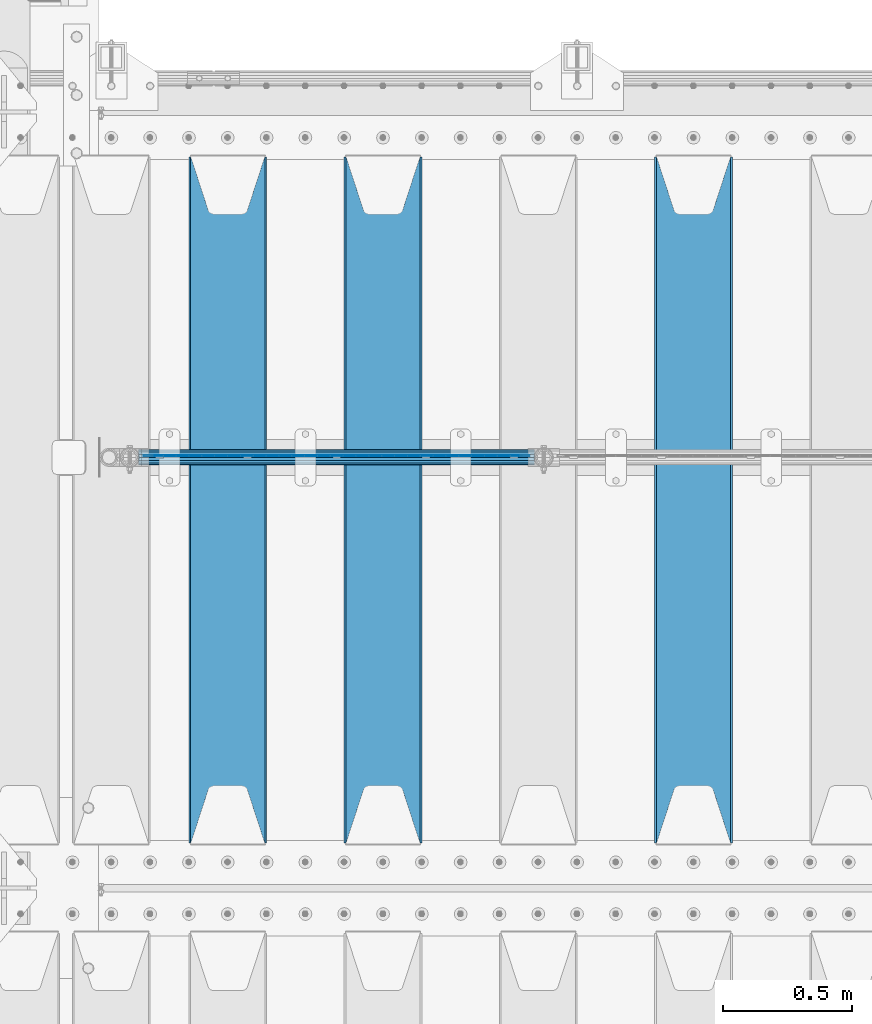
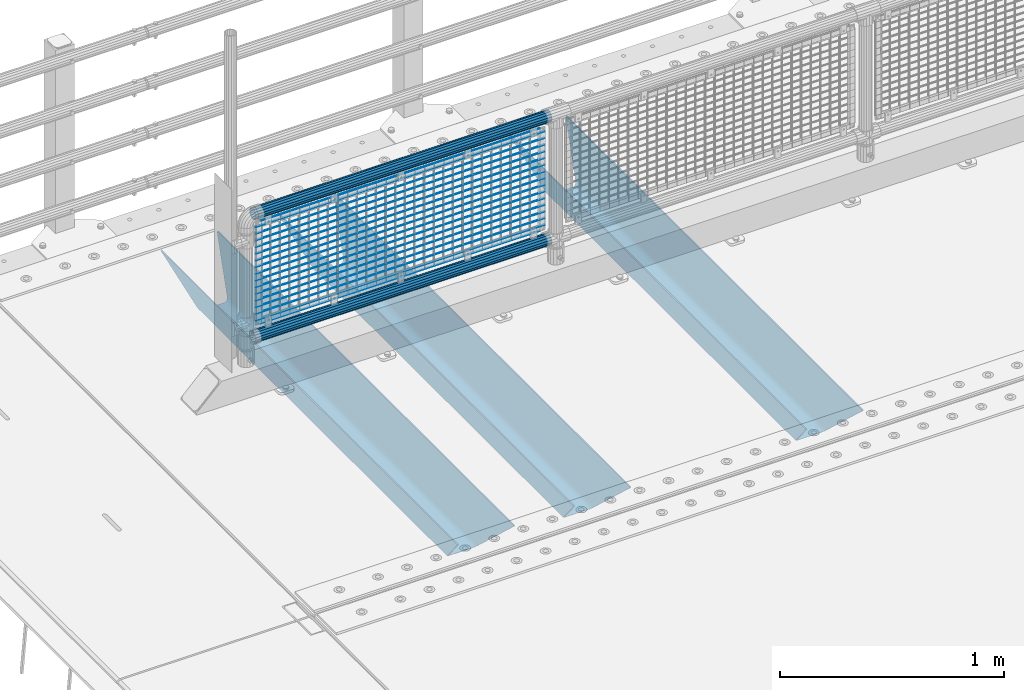
# One storey, part 115 of 257: 22 beams.
"""IFC2X3 building model written with IfcOpenShell, lengths in millimetres."""

from ifc_helpers import new_model, si_unit, frame, origin_with_axes, place, context, subcontext, project, spatial, faceted_brep, material, type_object, element, save


model = new_model("IFC2X3")

# Units and contexts
model_context = context("Model", 3, precision=1e-05, world=origin_with_axes())
body_context = subcontext(model_context, "Body", "Model", "MODEL_VIEW")
ifc_project = project(units=[si_unit("LENGTHUNIT", "METRE", prefix="MILLI"), si_unit("AREAUNIT", "SQUARE_METRE"), si_unit("VOLUMEUNIT", "CUBIC_METRE"), si_unit("MASSUNIT", "GRAM", prefix="KILO"), si_unit("TIMEUNIT", "SECOND"), si_unit("PLANEANGLEUNIT", "RADIAN"), si_unit("SOLIDANGLEUNIT", "STERADIAN"), si_unit("THERMODYNAMICTEMPERATUREUNIT", "DEGREE_CELSIUS"), si_unit("LUMINOUSINTENSITYUNIT", "LUMEN")], contexts=[model_context])

# Site, building, storey
site_placement = place(None, origin_with_axes())
site = spatial("IfcSite", under=ifc_project, at=site_placement, CompositionType="ELEMENT")
building_placement = place(site_placement, origin_with_axes())
building = spatial("IfcBuilding", under=site, at=building_placement, Name="Standard", CompositionType="ELEMENT")
storey_placement = place(building_placement, origin_with_axes())
storey = spatial("IfcBuildingStorey", under=building, at=storey_placement, Name="Undefined", CompositionType="ELEMENT", Elevation=0.0)

# Beams
ifc_material_1 = material(Name="STEEL/S355N")
beam_type_1 = type_object("IfcBeamType", PredefinedType="NOTDEFINED")
beam_1_placement = place(storey_placement, frame((45250.0, 9175.0, -115.0), z_axis=(0.0, 0.0, 1.0), x_axis=(0.0, 1.0, 0.0)))
element("IfcBeam", 1, at=beam_1_placement, inside=storey, type_object=beam_type_1, material=ifc_material_1, context=body_context, shape_type="Brep", body=[
    faceted_brep([(0.0, 150.0, 115.0), (0.0, 143.690000000002, 115.0), (2650.00000000297, 143.690000000002, 115.0), (2650.00000000297, 150.0, 115.0), (2650.00000000297, 142.059565218406, 110.0000000031), (2650.00000000297, 148.369565218403, 110.0000000031), (2441.90079219208, -80.1103600731149, -98.0992078077845), (2437.7588105432, -77.5672621345584, -102.241189456673), (2434.06523489746, -74.4080125315522, -105.934765102404), (2430.91086095089, -70.7102721255724, -109.089139048974), (2428.37322971128, -66.5649389910031, -111.626770288588), (2426.51472138055, -62.0739139532889, -113.485278619323), (2425.38102192091, -57.3475956567636, -114.618978078955), (2424.99999999987, -52.5021667386536, -115.0), (2424.99999999987, 52.5021667386536, -115.0), (2425.38102192091, 57.3475956567636, -114.618978078955), (2426.51472138055, 62.0739139532889, -113.485278619323), (2428.37322971128, 66.5649389910031, -111.626770288588), (2430.91086095089, 70.7102721255724, -109.089139048974), (2434.06523489746, 74.4080125315522, -105.934765102404), (2437.7588105432, 77.5672621345584, -102.241189456673), (2441.90079219208, 80.1103600731149, -98.0992078077846), (2446.38936140511, 81.9747917625791, -93.6106385947584), (2448.24948500409, 76.2713538057287, -91.7505149957729), (2444.62967112262, 74.76777986261, -95.3703288772456), (2441.28936334126, 72.7168944282894, -98.710636658607), (2438.31067330438, 70.1691124903809, -101.689326695487), (2435.76682334747, 67.1870637758839, -104.233176652398), (2433.72034654133, 63.8440531834931, -106.279653458539), (2432.22154950041, 60.2222587982324, -107.778450499454), (2431.30727574265, 56.4107117849126, -108.692724257221), (2430.99999999987, 52.5031078186876, -109.0), (2430.99999999987, -52.5031078186876, -109.0), (2431.30727574265, -56.4107117849126, -108.692724257221), (2432.22154950041, -60.2222587982324, -107.778450499454), (2433.72034654133, -63.8440531834931, -106.279653458539), (2435.76682334747, -67.1870637758839, -104.233176652398), (2438.31067330438, -70.1691124903809, -101.689326695487), (2441.28936334126, -72.7168944282894, -98.7106366586071), (2444.62967112262, -74.76777986261, -95.3703288772457), (2448.24948500409, -76.2713538057287, -91.7505149957729), (2650.00000000297, -142.059565218406, 110.0000000031), (2650.00000000297, -148.369565218403, 110.0000000031), (2446.38936140511, -81.9747917625791, -93.6106385947584), (2650.00000000297, -143.690000000002, 115.0), (2650.00000000297, -150.0, 115.0), (0.0, -143.690000000002, 115.0), (0.0, -150.0, 115.0), (0.0, -148.369565218258, 110.000000002662), (203.61063859742, -81.9747917625791, -93.6106385947584), (208.099207810447, -80.1103600731149, -98.0992078077845), (212.241189459335, -77.5672621345584, -102.241189456673), (215.934765105066, -74.4080125315522, -105.934765102404), (219.089139051636, -70.7102721255724, -109.089139048974), (221.626770291251, -66.5649389910031, -111.626770288588), (223.485278621985, -62.0739139532889, -113.485278619323), (224.618978081617, -57.3475956567636, -114.618978078955), (225.000000002662, -52.5021667386536, -115.0), (225.000000002662, 52.5021667386536, -115.0), (224.618978081617, 57.3475956567636, -114.618978078955), (223.485278621985, 62.0739139532889, -113.485278619323), (221.626770291251, 66.5649389910031, -111.626770288588), (219.089139051636, 70.7102721255724, -109.089139048974), (215.934765105066, 74.4080125315522, -105.934765102404), (212.241189459335, 77.5672621345584, -102.241189456673), (208.099207810447, 80.1103600731149, -98.0992078077846), (203.61063859742, 81.9747917625791, -93.6106385947584), (0.0, 148.369565218258, 110.000000002662), (0.0, 142.05956521826, 110.000000002662), (201.750514998435, 76.2713538057287, -91.7505149957729), (205.370328879908, 74.76777986261, -95.3703288772456), (208.710636661269, 72.7168944282894, -98.710636658607), (211.689326698149, 70.1691124903809, -101.689326695487), (214.233176655061, 67.1870637758839, -104.233176652398), (216.279653461201, 63.8440531834931, -106.279653458539), (217.778450502116, 60.2222587982324, -107.778450499454), (218.692724259884, 56.4107117849126, -108.692724257221), (219.000000002662, 52.5031078186876, -109.0), (219.000000002662, -52.5031078186876, -109.0), (218.692724259884, -56.4107117849126, -108.692724257221), (217.778450502116, -60.2222587982324, -107.778450499454), (216.279653461201, -63.8440531834931, -106.279653458539), (214.233176655061, -67.1870637758839, -104.233176652398), (211.689326698149, -70.1691124903809, -101.689326695487), (208.710636661269, -72.7168944282894, -98.7106366586071), (205.370328879908, -74.76777986261, -95.3703288772457), (201.750514998435, -76.2713538057287, -91.7505149957729), (0.0, -142.05956521826, 110.000000002662)], [[[0, 1, 2, 3]], [[3, 2, 4, 5]], [[6, 7, 8, 9, 10, 11, 12, 13, 14, 15, 16, 17, 18, 19, 20, 21, 22, 5, 4, 23, 24, 25, 26, 27, 28, 29, 30, 31, 32, 33, 34, 35, 36, 37, 38, 39, 40, 41, 42, 43]], [[44, 45, 42, 41]], [[46, 47, 45, 44]], [[43, 42, 45, 47, 48, 49]], [[6, 43, 49, 50]], [[7, 6, 50, 51]], [[8, 7, 51, 52]], [[9, 8, 52, 53]], [[10, 9, 53, 54]], [[11, 10, 54, 55]], [[12, 11, 55, 56]], [[13, 12, 56, 57]], [[14, 13, 57, 58]], [[15, 14, 58, 59]], [[16, 15, 59, 60]], [[17, 16, 60, 61]], [[18, 17, 61, 62]], [[19, 18, 62, 63]], [[20, 19, 63, 64]], [[21, 20, 64, 65]], [[22, 21, 65, 66]], [[0, 3, 5, 22, 66, 67]], [[1, 0, 67, 68]], [[23, 4, 2, 1, 68, 69]], [[24, 23, 69, 70]], [[25, 24, 70, 71]], [[26, 25, 71, 72]], [[27, 26, 72, 73]], [[28, 27, 73, 74]], [[29, 28, 74, 75]], [[30, 29, 75, 76]], [[31, 30, 76, 77]], [[32, 31, 77, 78]], [[33, 32, 78, 79]], [[34, 33, 79, 80]], [[35, 34, 80, 81]], [[36, 35, 81, 82]], [[37, 36, 82, 83]], [[38, 37, 83, 84]], [[39, 38, 84, 85]], [[40, 39, 85, 86]], [[46, 44, 41, 40, 86, 87]], [[47, 46, 87, 48]], [[86, 85, 84, 83, 82, 81, 80, 79, 78, 77, 76, 75, 74, 73, 72, 71, 70, 69, 68, 67, 66, 65, 64, 63, 62, 61, 60, 59, 58, 57, 56, 55, 54, 53, 52, 51, 50, 49, 48, 87]]]),
])
beam_2_placement = place(storey_placement, frame((44050.0, 9175.0, -115.0), z_axis=(0.0, 0.0, 1.0), x_axis=(0.0, 1.0, 0.0)))
element("IfcBeam", 2, at=beam_2_placement, inside=storey, type_object=beam_type_1, material=ifc_material_1, context=body_context, shape_type="Brep", body=[
    faceted_brep([(0.0, 150.0, 115.0), (0.0, 143.690000000002, 115.0), (2650.00000000297, 143.690000000002, 115.0), (2650.00000000297, 150.0, 115.0), (2650.00000000297, 142.059565218406, 110.0000000031), (2650.00000000297, 148.369565218403, 110.0000000031), (2441.90079219208, -80.1103600731149, -98.0992078077845), (2437.7588105432, -77.5672621345584, -102.241189456673), (2434.06523489746, -74.4080125315522, -105.934765102404), (2430.91086095089, -70.7102721255724, -109.089139048974), (2428.37322971128, -66.5649389910031, -111.626770288588), (2426.51472138055, -62.0739139532889, -113.485278619323), (2425.38102192091, -57.3475956567636, -114.618978078955), (2424.99999999987, -52.5021667386536, -115.0), (2424.99999999987, 52.5021667386536, -115.0), (2425.38102192091, 57.3475956567636, -114.618978078955), (2426.51472138055, 62.0739139532889, -113.485278619323), (2428.37322971128, 66.5649389910031, -111.626770288588), (2430.91086095089, 70.7102721255724, -109.089139048974), (2434.06523489746, 74.4080125315522, -105.934765102404), (2437.7588105432, 77.5672621345584, -102.241189456673), (2441.90079219208, 80.1103600731149, -98.0992078077846), (2446.38936140511, 81.9747917625791, -93.6106385947584), (2448.24948500409, 76.2713538057287, -91.7505149957729), (2444.62967112262, 74.76777986261, -95.3703288772456), (2441.28936334126, 72.7168944282894, -98.710636658607), (2438.31067330438, 70.1691124903809, -101.689326695487), (2435.76682334747, 67.1870637758839, -104.233176652398), (2433.72034654133, 63.8440531834931, -106.279653458539), (2432.22154950041, 60.2222587982324, -107.778450499454), (2431.30727574265, 56.4107117849126, -108.692724257221), (2430.99999999987, 52.5031078186876, -109.0), (2430.99999999987, -52.5031078186876, -109.0), (2431.30727574265, -56.4107117849126, -108.692724257221), (2432.22154950041, -60.2222587982324, -107.778450499454), (2433.72034654133, -63.8440531834931, -106.279653458539), (2435.76682334747, -67.1870637758839, -104.233176652398), (2438.31067330438, -70.1691124903809, -101.689326695487), (2441.28936334126, -72.7168944282894, -98.7106366586071), (2444.62967112262, -74.76777986261, -95.3703288772457), (2448.24948500409, -76.2713538057287, -91.7505149957729), (2650.00000000297, -142.059565218406, 110.0000000031), (2650.00000000297, -148.369565218403, 110.0000000031), (2446.38936140511, -81.9747917625791, -93.6106385947584), (2650.00000000297, -143.690000000002, 115.0), (2650.00000000297, -150.0, 115.0), (0.0, -143.690000000002, 115.0), (0.0, -150.0, 115.0), (0.0, -148.369565218258, 110.000000002662), (203.61063859742, -81.9747917625791, -93.6106385947584), (208.099207810447, -80.1103600731149, -98.0992078077845), (212.241189459335, -77.5672621345584, -102.241189456673), (215.934765105066, -74.4080125315522, -105.934765102404), (219.089139051636, -70.7102721255724, -109.089139048974), (221.626770291251, -66.5649389910031, -111.626770288588), (223.485278621985, -62.0739139532889, -113.485278619323), (224.618978081617, -57.3475956567636, -114.618978078955), (225.000000002662, -52.5021667386536, -115.0), (225.000000002662, 52.5021667386536, -115.0), (224.618978081617, 57.3475956567636, -114.618978078955), (223.485278621985, 62.0739139532889, -113.485278619323), (221.626770291251, 66.5649389910031, -111.626770288588), (219.089139051636, 70.7102721255724, -109.089139048974), (215.934765105066, 74.4080125315522, -105.934765102404), (212.241189459335, 77.5672621345584, -102.241189456673), (208.099207810447, 80.1103600731149, -98.0992078077846), (203.61063859742, 81.9747917625791, -93.6106385947584), (0.0, 148.369565218258, 110.000000002662), (0.0, 142.05956521826, 110.000000002662), (201.750514998435, 76.2713538057287, -91.7505149957729), (205.370328879908, 74.76777986261, -95.3703288772456), (208.710636661269, 72.7168944282894, -98.710636658607), (211.689326698149, 70.1691124903809, -101.689326695487), (214.233176655061, 67.1870637758839, -104.233176652398), (216.279653461201, 63.8440531834931, -106.279653458539), (217.778450502116, 60.2222587982324, -107.778450499454), (218.692724259884, 56.4107117849126, -108.692724257221), (219.000000002662, 52.5031078186876, -109.0), (219.000000002662, -52.5031078186876, -109.0), (218.692724259884, -56.4107117849126, -108.692724257221), (217.778450502116, -60.2222587982324, -107.778450499454), (216.279653461201, -63.8440531834931, -106.279653458539), (214.233176655061, -67.1870637758839, -104.233176652398), (211.689326698149, -70.1691124903809, -101.689326695487), (208.710636661269, -72.7168944282894, -98.7106366586071), (205.370328879908, -74.76777986261, -95.3703288772457), (201.750514998435, -76.2713538057287, -91.7505149957729), (0.0, -142.05956521826, 110.000000002662)], [[[0, 1, 2, 3]], [[3, 2, 4, 5]], [[6, 7, 8, 9, 10, 11, 12, 13, 14, 15, 16, 17, 18, 19, 20, 21, 22, 5, 4, 23, 24, 25, 26, 27, 28, 29, 30, 31, 32, 33, 34, 35, 36, 37, 38, 39, 40, 41, 42, 43]], [[44, 45, 42, 41]], [[46, 47, 45, 44]], [[43, 42, 45, 47, 48, 49]], [[6, 43, 49, 50]], [[7, 6, 50, 51]], [[8, 7, 51, 52]], [[9, 8, 52, 53]], [[10, 9, 53, 54]], [[11, 10, 54, 55]], [[12, 11, 55, 56]], [[13, 12, 56, 57]], [[14, 13, 57, 58]], [[15, 14, 58, 59]], [[16, 15, 59, 60]], [[17, 16, 60, 61]], [[18, 17, 61, 62]], [[19, 18, 62, 63]], [[20, 19, 63, 64]], [[21, 20, 64, 65]], [[22, 21, 65, 66]], [[0, 3, 5, 22, 66, 67]], [[1, 0, 67, 68]], [[23, 4, 2, 1, 68, 69]], [[24, 23, 69, 70]], [[25, 24, 70, 71]], [[26, 25, 71, 72]], [[27, 26, 72, 73]], [[28, 27, 73, 74]], [[29, 28, 74, 75]], [[30, 29, 75, 76]], [[31, 30, 76, 77]], [[32, 31, 77, 78]], [[33, 32, 78, 79]], [[34, 33, 79, 80]], [[35, 34, 80, 81]], [[36, 35, 81, 82]], [[37, 36, 82, 83]], [[38, 37, 83, 84]], [[39, 38, 84, 85]], [[40, 39, 85, 86]], [[46, 44, 41, 40, 86, 87]], [[47, 46, 87, 48]], [[86, 85, 84, 83, 82, 81, 80, 79, 78, 77, 76, 75, 74, 73, 72, 71, 70, 69, 68, 67, 66, 65, 64, 63, 62, 61, 60, 59, 58, 57, 56, 55, 54, 53, 52, 51, 50, 49, 48, 87]]]),
])
beam_3_placement = place(storey_placement, frame((43450.0, 9175.0, -115.0), z_axis=(0.0, 0.0, 1.0), x_axis=(0.0, 1.0, 0.0)))
element("IfcBeam", 3, at=beam_3_placement, inside=storey, type_object=beam_type_1, material=ifc_material_1, context=body_context, shape_type="Brep", body=[
    faceted_brep([(0.0, 150.0, 115.0), (0.0, 143.690000000002, 115.0), (2650.00000000297, 143.690000000002, 115.0), (2650.00000000297, 150.0, 115.0), (2650.00000000297, 142.059565218406, 110.0000000031), (2650.00000000297, 148.369565218403, 110.0000000031), (2441.90079219208, -80.1103600731149, -98.0992078077845), (2437.7588105432, -77.5672621345584, -102.241189456673), (2434.06523489746, -74.4080125315522, -105.934765102404), (2430.91086095089, -70.7102721255724, -109.089139048974), (2428.37322971128, -66.5649389910031, -111.626770288588), (2426.51472138055, -62.0739139532889, -113.485278619323), (2425.38102192091, -57.3475956567636, -114.618978078955), (2424.99999999987, -52.5021667386536, -115.0), (2424.99999999987, 52.5021667386536, -115.0), (2425.38102192091, 57.3475956567636, -114.618978078955), (2426.51472138055, 62.0739139532889, -113.485278619323), (2428.37322971128, 66.5649389910031, -111.626770288588), (2430.91086095089, 70.7102721255724, -109.089139048974), (2434.06523489746, 74.4080125315522, -105.934765102404), (2437.7588105432, 77.5672621345584, -102.241189456673), (2441.90079219208, 80.1103600731149, -98.0992078077846), (2446.38936140511, 81.9747917625791, -93.6106385947584), (2448.24948500409, 76.2713538057287, -91.7505149957729), (2444.62967112262, 74.76777986261, -95.3703288772456), (2441.28936334126, 72.7168944282894, -98.710636658607), (2438.31067330438, 70.1691124903809, -101.689326695487), (2435.76682334747, 67.1870637758839, -104.233176652398), (2433.72034654133, 63.8440531834931, -106.279653458539), (2432.22154950041, 60.2222587982324, -107.778450499454), (2431.30727574265, 56.4107117849126, -108.692724257221), (2430.99999999987, 52.5031078186876, -109.0), (2430.99999999987, -52.5031078186876, -109.0), (2431.30727574265, -56.4107117849126, -108.692724257221), (2432.22154950041, -60.2222587982324, -107.778450499454), (2433.72034654133, -63.8440531834931, -106.279653458539), (2435.76682334747, -67.1870637758839, -104.233176652398), (2438.31067330438, -70.1691124903809, -101.689326695487), (2441.28936334126, -72.7168944282894, -98.7106366586071), (2444.62967112262, -74.76777986261, -95.3703288772457), (2448.24948500409, -76.2713538057287, -91.7505149957729), (2650.00000000297, -142.059565218406, 110.0000000031), (2650.00000000297, -148.369565218403, 110.0000000031), (2446.38936140511, -81.9747917625791, -93.6106385947584), (2650.00000000297, -143.690000000002, 115.0), (2650.00000000297, -150.0, 115.0), (0.0, -143.690000000002, 115.0), (0.0, -150.0, 115.0), (0.0, -148.369565218258, 110.000000002662), (203.61063859742, -81.9747917625791, -93.6106385947584), (208.099207810447, -80.1103600731149, -98.0992078077845), (212.241189459335, -77.5672621345584, -102.241189456673), (215.934765105066, -74.4080125315522, -105.934765102404), (219.089139051636, -70.7102721255724, -109.089139048974), (221.626770291251, -66.5649389910031, -111.626770288588), (223.485278621985, -62.0739139532889, -113.485278619323), (224.618978081617, -57.3475956567636, -114.618978078955), (225.000000002662, -52.5021667386536, -115.0), (225.000000002662, 52.5021667386536, -115.0), (224.618978081617, 57.3475956567636, -114.618978078955), (223.485278621985, 62.0739139532889, -113.485278619323), (221.626770291251, 66.5649389910031, -111.626770288588), (219.089139051636, 70.7102721255724, -109.089139048974), (215.934765105066, 74.4080125315522, -105.934765102404), (212.241189459335, 77.5672621345584, -102.241189456673), (208.099207810447, 80.1103600731149, -98.0992078077846), (203.61063859742, 81.9747917625791, -93.6106385947584), (0.0, 148.369565218258, 110.000000002662), (0.0, 142.05956521826, 110.000000002662), (201.750514998435, 76.2713538057287, -91.7505149957729), (205.370328879908, 74.76777986261, -95.3703288772456), (208.710636661269, 72.7168944282894, -98.710636658607), (211.689326698149, 70.1691124903809, -101.689326695487), (214.233176655061, 67.1870637758839, -104.233176652398), (216.279653461201, 63.8440531834931, -106.279653458539), (217.778450502116, 60.2222587982324, -107.778450499454), (218.692724259884, 56.4107117849126, -108.692724257221), (219.000000002662, 52.5031078186876, -109.0), (219.000000002662, -52.5031078186876, -109.0), (218.692724259884, -56.4107117849126, -108.692724257221), (217.778450502116, -60.2222587982324, -107.778450499454), (216.279653461201, -63.8440531834931, -106.279653458539), (214.233176655061, -67.1870637758839, -104.233176652398), (211.689326698149, -70.1691124903809, -101.689326695487), (208.710636661269, -72.7168944282894, -98.7106366586071), (205.370328879908, -74.76777986261, -95.3703288772457), (201.750514998435, -76.2713538057287, -91.7505149957729), (0.0, -142.05956521826, 110.000000002662)], [[[0, 1, 2, 3]], [[3, 2, 4, 5]], [[6, 7, 8, 9, 10, 11, 12, 13, 14, 15, 16, 17, 18, 19, 20, 21, 22, 5, 4, 23, 24, 25, 26, 27, 28, 29, 30, 31, 32, 33, 34, 35, 36, 37, 38, 39, 40, 41, 42, 43]], [[44, 45, 42, 41]], [[46, 47, 45, 44]], [[43, 42, 45, 47, 48, 49]], [[6, 43, 49, 50]], [[7, 6, 50, 51]], [[8, 7, 51, 52]], [[9, 8, 52, 53]], [[10, 9, 53, 54]], [[11, 10, 54, 55]], [[12, 11, 55, 56]], [[13, 12, 56, 57]], [[14, 13, 57, 58]], [[15, 14, 58, 59]], [[16, 15, 59, 60]], [[17, 16, 60, 61]], [[18, 17, 61, 62]], [[19, 18, 62, 63]], [[20, 19, 63, 64]], [[21, 20, 64, 65]], [[22, 21, 65, 66]], [[0, 3, 5, 22, 66, 67]], [[1, 0, 67, 68]], [[23, 4, 2, 1, 68, 69]], [[24, 23, 69, 70]], [[25, 24, 70, 71]], [[26, 25, 71, 72]], [[27, 26, 72, 73]], [[28, 27, 73, 74]], [[29, 28, 74, 75]], [[30, 29, 75, 76]], [[31, 30, 76, 77]], [[32, 31, 77, 78]], [[33, 32, 78, 79]], [[34, 33, 79, 80]], [[35, 34, 80, 81]], [[36, 35, 81, 82]], [[37, 36, 82, 83]], [[38, 37, 83, 84]], [[39, 38, 84, 85]], [[40, 39, 85, 86]], [[46, 44, 41, 40, 86, 87]], [[47, 46, 87, 48]], [[86, 85, 84, 83, 82, 81, 80, 79, 78, 77, 76, 75, 74, 73, 72, 71, 70, 69, 68, 67, 66, 65, 64, 63, 62, 61, 60, 59, 58, 57, 56, 55, 54, 53, 52, 51, 50, 49, 48, 87]]]),
])
ifc_material_2 = material(Name="Misc_Undefined")
beam_type_2 = type_object("IfcBeamType", Name="D3", PredefinedType="NOTDEFINED")
for number, where, z_axis, x_axis in (
    (4, (43126.0, 10670.5, 851.596999999999), (0.0, 0.0, 1.0), (1.0, 0.0, 0.0)),
    (5, (43126.0, 10670.5, 669.452), (0.0, 0.0, 1.0), (1.0, 0.0, 0.0)),
    (6, (43126.0, 10670.5, 523.736), (0.0, 0.0, 1.0), (1.0, 0.0, 0.0)),
    (7, (43126.0, 10670.5, 487.307), (0.0, 0.0, 1.0), (1.0, 0.0, 0.0)),
    (8, (43126.0, 10670.5, 705.881), (0.0, 0.0, 1.0), (1.0, 0.0, 0.0)),
    (9, (43126.0, 10670.5, 596.594), (0.0, 0.0, 1.0), (1.0, 0.0, 0.0)),
    (10, (43126.0, 10670.5, 450.878), (0.0, 0.0, 1.0), (1.0, 0.0, 0.0)),
    (11, (43126.0, 10670.5, 815.167999999999), (0.0, 0.0, 1.0), (1.0, 0.0, 0.0)),
    (12, (43126.0, 10670.5, 888.025999999999), (0.0, 0.0, 1.0), (1.0, 0.0, 0.0)),
    (13, (43126.0, 10670.5, 778.738999999999), (0.0, 0.0, 1.0), (1.0, 0.0, 0.0)),
    (14, (43126.0, 10670.5, 742.309999999999), (0.0, 0.0, 1.0), (1.0, 0.0, 0.0)),
    (15, (43126.0, 10670.5, 633.023), (0.0, 0.0, 1.0), (1.0, 0.0, 0.0)),
    (16, (43126.0, 10670.5, 560.165), (0.0, 0.0, 1.0), (1.0, 0.0, 0.0)),
    (17, (43126.0, 10670.5, 414.449), (0.0, 0.0, 1.0), (1.0, 0.0, 0.0)),
):
    element("IfcBeam", number, at=place(storey_placement, frame(where, z_axis=z_axis, x_axis=x_axis)), inside=storey, type_object=beam_type_2, material=ifc_material_2, ObjectType="D3", context=body_context, shape_type="Brep", body=[
        faceted_brep([(0.0, -1.5, -5.6843418860808e-14), (0.0, -0.750000000001819, -1.29903810567669), (1490.0, -0.75, -1.29903810567669), (1490.0, -1.5, 0.0), (7.27595761418343e-12, 0.749999999998181, -1.29903810567669), (1490.0, 0.75, -1.29903810567669), (0.0, 1.5, -5.6843418860808e-14), (1490.0, 1.5, 0.0), (7.27595761418343e-12, 0.749999999998181, 1.29903810567669), (1490.0, 0.75, 1.29903810567669), (0.0, -0.750000000001819, 1.29903810567669), (1490.0, -0.75, 1.29903810567669)], [[[0, 1, 2, 3]], [[1, 4, 5, 2]], [[4, 6, 7, 5]], [[6, 8, 9, 7]], [[8, 10, 11, 9]], [[10, 0, 3, 11]], [[5, 7, 9, 11, 3, 2]], [[10, 8, 6, 4, 1, 0]]]),
    ])
beam_4_placement = place(storey_placement, frame((43151.0, 10670.5, 353.02), z_axis=(0.0, 0.0, 1.0), x_axis=(1.0, 0.0, 0.0)))
element("IfcBeam", 18, at=beam_4_placement, inside=storey, type_object=beam_type_2, material=ifc_material_2, ObjectType="D3", context=body_context, shape_type="Brep", body=[
    faceted_brep([(0.0, -1.5, -5.6843418860808e-14), (0.0, -0.750000000001819, -1.29903810567669), (1440.0, -0.75, -1.29903810567669), (1440.0, -1.5, 0.0), (7.27595761418343e-12, 0.749999999998181, -1.29903810567669), (1440.0, 0.75, -1.29903810567663), (0.0, 1.5, -5.6843418860808e-14), (1440.0, 1.5, 0.0), (7.27595761418343e-12, 0.749999999998181, 1.29903810567669), (1440.0, 0.75, 1.29903810567669), (0.0, -0.750000000001819, 1.29903810567669), (1440.0, -0.75, 1.29903810567669)], [[[0, 1, 2, 3]], [[1, 4, 5, 2]], [[4, 6, 7, 5]], [[6, 8, 9, 7]], [[8, 10, 11, 9]], [[10, 0, 3, 11]], [[5, 7, 9, 11, 3, 2]], [[10, 8, 6, 4, 1, 0]]]),
])
beam_5_placement = place(storey_placement, frame((43126.0, 10670.5, 378.02), z_axis=(0.0, 0.0, 1.0), x_axis=(1.0, 0.0, 0.0)))
element("IfcBeam", 19, at=beam_5_placement, inside=storey, type_object=beam_type_2, material=ifc_material_2, ObjectType="D3", context=body_context, shape_type="Brep", body=[
    faceted_brep([(0.0, -1.5, -5.6843418860808e-14), (0.0, -0.750000000001819, -1.29903810567669), (1490.0, -0.75, -1.29903810567669), (1490.0, -1.5, 0.0), (7.27595761418343e-12, 0.749999999998181, -1.29903810567669), (1490.0, 0.75, -1.29903810567669), (0.0, 1.5, -5.6843418860808e-14), (1490.0, 1.5, 0.0), (7.27595761418343e-12, 0.749999999998181, 1.29903810567669), (1490.0, 0.75, 1.29903810567669), (0.0, -0.750000000001819, 1.29903810567669), (1490.0, -0.75, 1.29903810567669)], [[[0, 1, 2, 3]], [[1, 4, 5, 2]], [[4, 6, 7, 5]], [[6, 8, 9, 7]], [[8, 10, 11, 9]], [[10, 0, 3, 11]], [[5, 7, 9, 11, 3, 2]], [[10, 8, 6, 4, 1, 0]]]),
])
beam_6_placement = place(storey_placement, frame((43151.0, 10670.5, 913.02), z_axis=(0.0, 0.0, 1.0), x_axis=(1.0, 0.0, 0.0)))
element("IfcBeam", 20, at=beam_6_placement, inside=storey, type_object=beam_type_2, material=ifc_material_2, ObjectType="D3", context=body_context, shape_type="Brep", body=[
    faceted_brep([(0.0, -1.5, -5.6843418860808e-14), (0.0, -0.750000000001819, -1.29903810567669), (1440.0, -0.75, -1.29903810567669), (1440.0, -1.5, 0.0), (7.27595761418343e-12, 0.749999999998181, -1.29903810567669), (1440.0, 0.75, -1.29903810567663), (0.0, 1.5, -5.6843418860808e-14), (1440.0, 1.5, 0.0), (7.27595761418343e-12, 0.749999999998181, 1.29903810567669), (1440.0, 0.75, 1.29903810567669), (0.0, -0.750000000001819, 1.29903810567669), (1440.0, -0.75, 1.29903810567669)], [[[0, 1, 2, 3]], [[1, 4, 5, 2]], [[4, 6, 7, 5]], [[6, 8, 9, 7]], [[8, 10, 11, 9]], [[10, 0, 3, 11]], [[5, 7, 9, 11, 3, 2]], [[10, 8, 6, 4, 1, 0]]]),
])
ifc_material_3 = material()
beam_type_3 = type_object("IfcBeamType", PredefinedType="NOTDEFINED")
beam_7_placement = place(storey_placement, frame((43105.85, 10664.5, 969.849999999999), z_axis=(0.0, 0.0, 1.0), x_axis=(1.0, 0.0, 0.0)))
element("IfcBeam", 21, at=beam_7_placement, inside=storey, type_object=beam_type_3, material=ifc_material_3, context=body_context, shape_type="Brep", body=[
    faceted_brep([(0.0, -25.3500000000004, 0.0), (0.0, -23.4203461491616, 9.70102501045767), (1530.0, -23.4203461491616, 9.70102501045506), (1530.0, -25.3500000000004, 0.0), (0.0, -17.9251569030785, 17.9251569030821), (1530.0, -17.9251569030785, 17.925156903079), (0.0, -9.70102501045585, 23.4203461491634), (1530.0, -9.70102501045585, 23.4203461491611), (0.0, 0.0, 25.3499999999985), (1530.0, 0.0, 25.35), (0.0, 9.70102501045585, 23.4203461491634), (1530.0, 9.70102501045585, 23.4203461491611), (0.0, 17.9251569030785, 17.9251569030821), (1530.0, 17.9251569030785, 17.925156903079), (0.0, 23.4203461491616, 9.70102501045767), (1530.0, 23.4203461491616, 9.701025010455), (0.0, 25.3500000000004, 0.0), (1530.0, 25.3500000000004, 0.0), (0.0, 23.4203461491616, -9.70102501045767), (1530.0, 23.4203461491616, -9.70102501045506), (0.0, 17.9251569030785, -17.9251569030821), (1530.0, 17.9251569030785, -17.925156903079), (0.0, 9.70102501045585, -23.4203461491634), (1530.0, 9.70102501045585, -23.4203461491611), (0.0, 0.0, -25.3499999999985), (1530.0, 0.0, -25.35), (0.0, -9.70102501045585, -23.4203461491634), (1530.0, -9.70102501045585, -23.4203461491611), (0.0, -17.9251569030785, -17.9251569030821), (1530.0, -17.9251569030785, -17.925156903079), (0.0, -23.4203461491616, -9.70102501045767), (1530.0, -23.4203461491616, -9.701025010455), (0.0, -30.1499999999996, 0.0), (0.0, -27.8549679052157, -11.5379054858058), (1530.0, -27.8549679052157, -11.5379054858075), (1530.0, -30.1499999999996, 0.0), (0.0, -21.3192694527752, -21.3192694527752), (1530.0, -21.3192694527752, -21.3192694527744), (0.0, -11.5379054858076, -27.8549679052157), (1530.0, -11.5379054858076, -27.8549679052153), (0.0, 0.0, -30.1500000000015), (1530.0, 0.0, -30.15), (0.0, 11.5379054858076, -27.8549679052157), (1530.0, 11.5379054858076, -27.8549679052153), (0.0, 21.3192694527752, -21.3192694527752), (1530.0, 21.3192694527752, -21.3192694527744), (0.0, 27.8549679052157, -11.5379054858058), (1530.0, 27.8549679052157, -11.5379054858075), (0.0, 30.1499999999996, 0.0), (1530.0, 30.1499999999996, 0.0), (0.0, 27.8549679052157, 11.5379054858058), (1530.0, 27.8549679052157, 11.5379054858075), (0.0, 21.3192694527752, 21.3192694527752), (1530.0, 21.3192694527752, 21.3192694527744), (0.0, 11.5379054858076, 27.8549679052157), (1530.0, 11.5379054858076, 27.8549679052153), (0.0, 0.0, 30.1500000000015), (1530.0, 0.0, 30.15), (0.0, -11.5379054858076, 27.8549679052157), (1530.0, -11.5379054858076, 27.8549679052153), (0.0, -21.3192694527752, 21.3192694527752), (1530.0, -21.3192694527752, 21.3192694527744), (0.0, -27.8549679052157, 11.5379054858058), (1530.0, -27.8549679052157, 11.5379054858075)], [[[0, 1, 2, 3]], [[1, 4, 5, 2]], [[4, 6, 7, 5]], [[6, 8, 9, 7]], [[8, 10, 11, 9]], [[10, 12, 13, 11]], [[12, 14, 15, 13]], [[14, 16, 17, 15]], [[16, 18, 19, 17]], [[18, 20, 21, 19]], [[20, 22, 23, 21]], [[22, 24, 25, 23]], [[24, 26, 27, 25]], [[26, 28, 29, 27]], [[28, 30, 31, 29]], [[30, 0, 3, 31]], [[32, 33, 34, 35]], [[33, 36, 37, 34]], [[36, 38, 39, 37]], [[38, 40, 41, 39]], [[40, 42, 43, 41]], [[42, 44, 45, 43]], [[44, 46, 47, 45]], [[46, 48, 49, 47]], [[48, 50, 51, 49]], [[50, 52, 53, 51]], [[52, 54, 55, 53]], [[54, 56, 57, 55]], [[56, 58, 59, 57]], [[58, 60, 61, 59]], [[60, 62, 63, 61]], [[62, 32, 35, 63]], [[37, 39, 41, 43, 45, 47, 49, 51, 53, 55, 57, 59, 61, 63, 35, 34], [5, 7, 9, 11, 13, 15, 17, 19, 21, 23, 25, 27, 29, 31, 3, 2]], [[62, 60, 58, 56, 54, 52, 50, 48, 46, 44, 42, 40, 38, 36, 33, 32], [30, 28, 26, 24, 22, 20, 18, 16, 14, 12, 10, 8, 6, 4, 1, 0]]]),
])
beam_8_placement = place(storey_placement, frame((43105.85, 10664.5, 298.170000000001), z_axis=(0.0, 0.0, 1.0), x_axis=(1.0, 0.0, 0.0)))
element("IfcBeam", 22, at=beam_8_placement, inside=storey, type_object=beam_type_3, material=ifc_material_3, context=body_context, shape_type="Brep", body=[
    faceted_brep([(0.0, -25.3500000000004, 0.0), (0.0, -23.4203461491616, 9.70102501045767), (1530.0, -23.4203461491616, 9.70102501045506), (1530.0, -25.3500000000004, 0.0), (0.0, -17.9251569030785, 17.9251569030821), (1530.0, -17.9251569030785, 17.925156903079), (0.0, -9.70102501045585, 23.4203461491634), (1530.0, -9.70102501045585, 23.4203461491611), (0.0, 0.0, 25.3499999999985), (1530.0, 0.0, 25.35), (0.0, 9.70102501045585, 23.4203461491634), (1530.0, 9.70102501045585, 23.4203461491611), (0.0, 17.9251569030785, 17.9251569030821), (1530.0, 17.9251569030785, 17.925156903079), (0.0, 23.4203461491616, 9.70102501045767), (1530.0, 23.4203461491616, 9.701025010455), (0.0, 25.3500000000004, 0.0), (1530.0, 25.3500000000004, 0.0), (0.0, 23.4203461491616, -9.70102501045767), (1530.0, 23.4203461491616, -9.70102501045506), (0.0, 17.9251569030785, -17.9251569030821), (1530.0, 17.9251569030785, -17.925156903079), (0.0, 9.70102501045585, -23.4203461491634), (1530.0, 9.70102501045585, -23.4203461491611), (0.0, 0.0, -25.3499999999985), (1530.0, 0.0, -25.35), (0.0, -9.70102501045585, -23.4203461491634), (1530.0, -9.70102501045585, -23.4203461491611), (0.0, -17.9251569030785, -17.9251569030821), (1530.0, -17.9251569030785, -17.925156903079), (0.0, -23.4203461491616, -9.70102501045767), (1530.0, -23.4203461491616, -9.701025010455), (0.0, -30.1499999999996, 0.0), (0.0, -27.8549679052157, -11.5379054858058), (1530.0, -27.8549679052157, -11.5379054858075), (1530.0, -30.1499999999996, 0.0), (0.0, -21.3192694527752, -21.3192694527752), (1530.0, -21.3192694527752, -21.3192694527744), (0.0, -11.5379054858076, -27.8549679052157), (1530.0, -11.5379054858076, -27.8549679052153), (0.0, 0.0, -30.1500000000015), (1530.0, 0.0, -30.15), (0.0, 11.5379054858076, -27.8549679052157), (1530.0, 11.5379054858076, -27.8549679052153), (0.0, 21.3192694527752, -21.3192694527752), (1530.0, 21.3192694527752, -21.3192694527744), (0.0, 27.8549679052157, -11.5379054858058), (1530.0, 27.8549679052157, -11.5379054858075), (0.0, 30.1499999999996, 0.0), (1530.0, 30.1499999999996, 0.0), (0.0, 27.8549679052157, 11.5379054858058), (1530.0, 27.8549679052157, 11.5379054858075), (0.0, 21.3192694527752, 21.3192694527752), (1530.0, 21.3192694527752, 21.3192694527744), (0.0, 11.5379054858076, 27.8549679052157), (1530.0, 11.5379054858076, 27.8549679052153), (0.0, 0.0, 30.1500000000015), (1530.0, 0.0, 30.15), (0.0, -11.5379054858076, 27.8549679052157), (1530.0, -11.5379054858076, 27.8549679052153), (0.0, -21.3192694527752, 21.3192694527752), (1530.0, -21.3192694527752, 21.3192694527744), (0.0, -27.8549679052157, 11.5379054858058), (1530.0, -27.8549679052157, 11.5379054858075)], [[[0, 1, 2, 3]], [[1, 4, 5, 2]], [[4, 6, 7, 5]], [[6, 8, 9, 7]], [[8, 10, 11, 9]], [[10, 12, 13, 11]], [[12, 14, 15, 13]], [[14, 16, 17, 15]], [[16, 18, 19, 17]], [[18, 20, 21, 19]], [[20, 22, 23, 21]], [[22, 24, 25, 23]], [[24, 26, 27, 25]], [[26, 28, 29, 27]], [[28, 30, 31, 29]], [[30, 0, 3, 31]], [[32, 33, 34, 35]], [[33, 36, 37, 34]], [[36, 38, 39, 37]], [[38, 40, 41, 39]], [[40, 42, 43, 41]], [[42, 44, 45, 43]], [[44, 46, 47, 45]], [[46, 48, 49, 47]], [[48, 50, 51, 49]], [[50, 52, 53, 51]], [[52, 54, 55, 53]], [[54, 56, 57, 55]], [[56, 58, 59, 57]], [[58, 60, 61, 59]], [[60, 62, 63, 61]], [[62, 32, 35, 63]], [[37, 39, 41, 43, 45, 47, 49, 51, 53, 55, 57, 59, 61, 63, 35, 34], [5, 7, 9, 11, 13, 15, 17, 19, 21, 23, 25, 27, 29, 31, 3, 2]], [[62, 60, 58, 56, 54, 52, 50, 48, 46, 44, 42, 40, 38, 36, 33, 32], [30, 28, 26, 24, 22, 20, 18, 16, 14, 12, 10, 8, 6, 4, 1, 0]]]),
])

save(model, "model.ifc")
